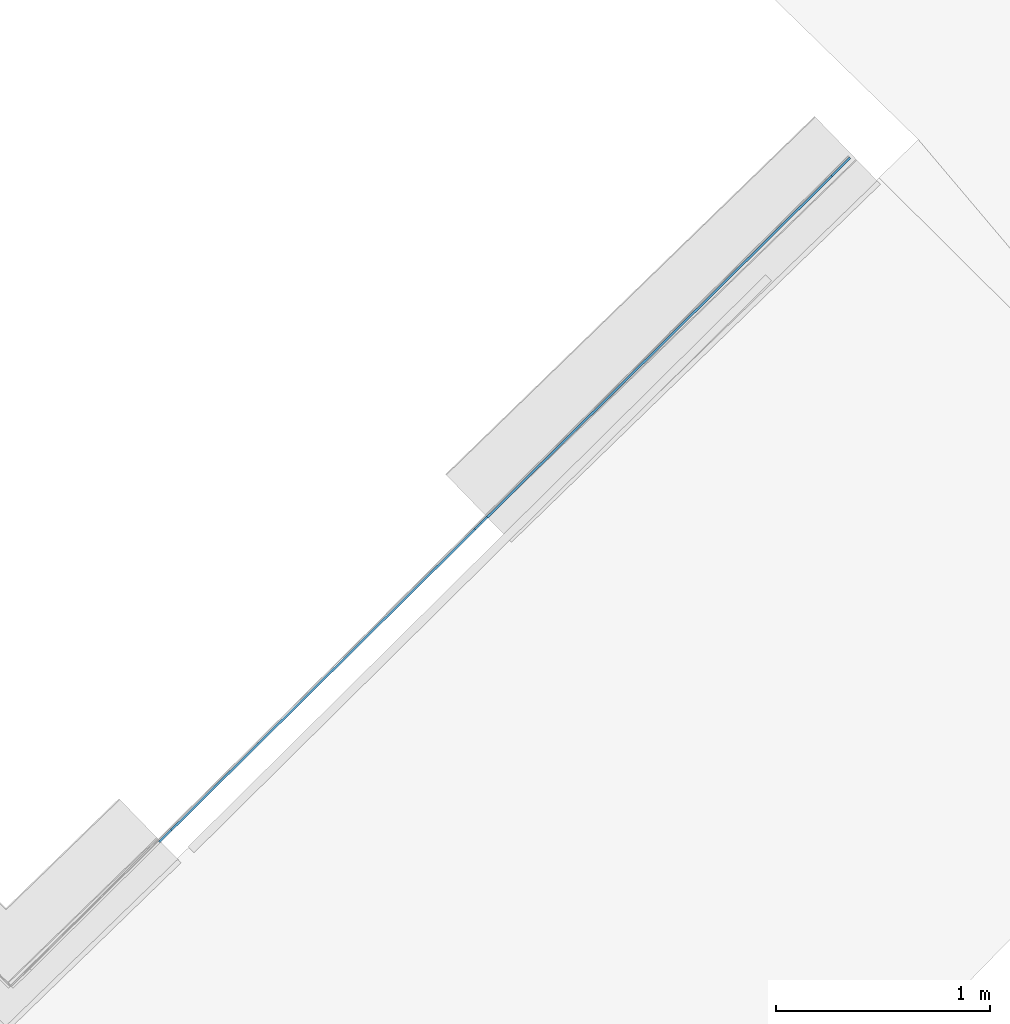
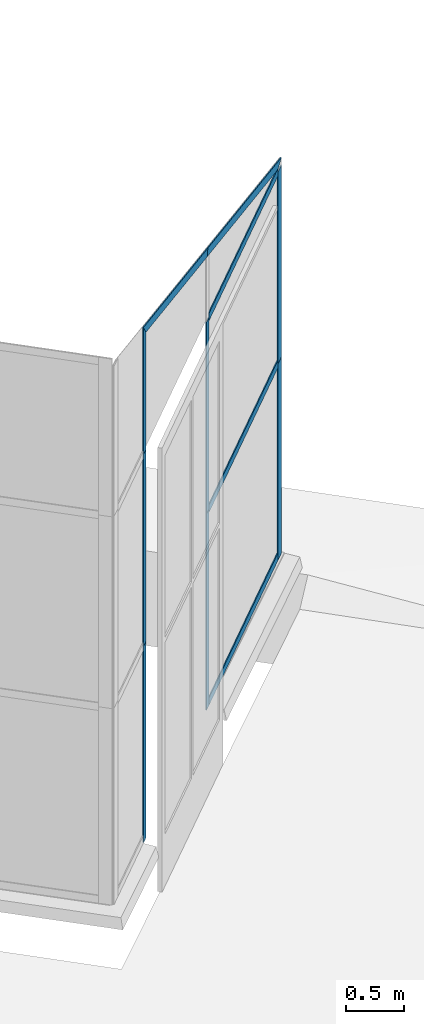
# One storey, part 3 of 13: 12 members, 1 element without a shape of its own.
"""IFC4 building model written with IfcOpenShell, lengths in metres."""

from ifc_helpers import new_model, entity, si_unit, converted_unit, direction, frame, origin, place, context, subcontext, project, spatial, indexed_curve, outline, extrude, source, transform, mapped, material, type_object, type_shapes, element, aggregate, save


model = new_model("IFC4")

# Units and contexts
model_context = context("Model", 3, precision=1e-05, world=origin(), true_north=direction((6.123233995736766e-17, 1.0)))
body_context = subcontext(model_context, "Body", "Model", "MODEL_VIEW")
ifc_project = project(units=[si_unit("LENGTHUNIT", "METRE"), si_unit("AREAUNIT", "SQUARE_METRE"), si_unit("VOLUMEUNIT", "CUBIC_METRE"), converted_unit("PLANEANGLEUNIT", "DEGREE", entity("IfcPlaneAngleMeasure", 0.017453292519943278), si_unit("PLANEANGLEUNIT", "RADIAN"), dimensions=[0, 0, 0, 0, 0, 0, 0])], contexts=[model_context])

# Site, building, storey
site_placement = place(None, frame((0.0, 0.0, 0.0), z_axis=(0.0, 0.0, 1.0), x_axis=(0.7160934825303189, -0.6980043870045516, 0.0)))
site = spatial("IfcSite", under=ifc_project, at=site_placement, CompositionType="ELEMENT")
building_placement = place(site_placement, origin())
building = spatial("IfcBuilding", under=site, at=building_placement, CompositionType="ELEMENT")
storey_placement = place(building_placement, frame((0.0, 0.0, -7.0)))
storey = spatial("IfcBuildingStorey", under=building, at=storey_placement, Name="-7.00 m", CompositionType="ELEMENT", Elevation=-7.000000000000001)

# Curtain wall, members
curtain_wall_type = type_object("IfcCurtainWallType", Name="Facciata continua:Vetrata_1", PredefinedType="NOTDEFINED")
curtain_wall_placement = place(storey_placement, frame((0.0, 0.0, 7.0)))
curtain_wall = element("IfcCurtainWall", 1, at=curtain_wall_placement, inside=storey, type_object=curtain_wall_type, Name="Facciata continua:Vetrata_1", ObjectType="Facciata continua:Vetrata_1", PredefinedType="NOTDEFINED")
ifc_material = material(Name="Acciaio", Category="Metallo")
member_type_1 = type_object("IfcMemberType", Name="Montante rettangolare:Montante rettangolare 3", PredefinedType="MULLION", material=ifc_material)
shared_shape_1 = source(origin(), body_context, "Body", "SweptSolid", [
    extrude(outline(indexed_curve([(-0.06, -0.004999999999999997), (0.06, -0.004999999999999997), (0.06, 0.004999999999999997), (-0.06, 0.004999999999999997), (-0.06, -0.004999999999999997)], self_intersect=False)), frame((-0.06, 0.009999999999999993, -2.0800000000000005), z_axis=(0.0, 0.0, 1.0), x_axis=(-1.0, 0.0, 0.0)), (0.0, 0.0, 1.0), 2.0800000000000005),
])
type_shapes(member_type_1, [shared_shape_1])
member_1_placement = place(curtain_wall_placement, frame((8.439099009840033, -1.4710459050843856, -6.94), z_axis=(0.0, 0.0, -1.0), x_axis=(0.017636182236115534, 0.9998444704433458, 0.0)))
member_1 = element("IfcMember", 2, at=member_1_placement, type_object=member_type_1, material=ifc_material, Name="Montante rettangolare:Montante rettangolare 3", ObjectType="Montante rettangolare:Montante rettangolare 3", PredefinedType="MULLION", context=body_context, shape_type="MappedRepresentation", body=[
    mapped(shared_shape_1, transform((0.0, 0.0, 0.0), scale=1.0)),
])
member_type_2 = type_object("IfcMemberType", Name="Montante rettangolare:Montante rettangolare 3", PredefinedType="MULLION", material=ifc_material)
shared_shape_2 = source(origin(), body_context, "Body", "SweptSolid", [
    extrude(outline(indexed_curve([(-0.06, -0.004999999999999997), (0.06, -0.004999999999999997), (0.06, 0.004999999999999997), (-0.06, 0.004999999999999997), (-0.06, -0.004999999999999997)], self_intersect=False)), frame((-0.06, 0.009999999999999993, -2.030000000000001), z_axis=(0.0, 0.0, 1.0), x_axis=(-1.0, 0.0, 0.0)), (0.0, 0.0, 1.0), 2.030000000000001),
])
type_shapes(member_type_2, [shared_shape_2])
member_2_placement = place(curtain_wall_placement, frame((8.439099009840033, -1.4710459050843856, -4.86), z_axis=(0.0, 0.0, -1.0), x_axis=(0.017636182236115534, 0.9998444704433458, 0.0)))
member_2 = element("IfcMember", 3, at=member_2_placement, type_object=member_type_2, material=ifc_material, Name="Montante rettangolare:Montante rettangolare 3", ObjectType="Montante rettangolare:Montante rettangolare 3", PredefinedType="MULLION", context=body_context, shape_type="MappedRepresentation", body=[
    mapped(shared_shape_2, transform((0.0, 0.0, 0.0), scale=1.0)),
])
member_type_3 = type_object("IfcMemberType", Name="Montante rettangolare:Montante rettangolare 2", PredefinedType="MULLION", material=ifc_material)
shared_shape_3 = source(origin(), body_context, "Body", "SweptSolid", [
    extrude(outline(indexed_curve([(-1.284408025415731, -0.04), (1.2332732224483656, -0.04), (1.2332732224483656, 0.04), (-1.1821384194810003, 0.04), (-1.284408025415731, -0.04)], self_intersect=False)), frame((-0.04, 0.004999999999999997, -1.28440802541573), z_axis=(0.0, 1.0, 0.0), x_axis=(0.0, 0.0, -1.0)), (0.0, 0.0, 1.0), 0.010000000000000002),
])
type_shapes(member_type_3, [shared_shape_3])
member_3_placement = place(curtain_wall_placement, frame((8.439099009840035, -1.4710459050843858, -2.750831472247348), z_axis=(0.016988025387663693, 0.9630986468728898, -0.26861199411984027), x_axis=(0.004737290079103897, 0.26857021701548284, 0.9632484604788959)))
member_3 = element("IfcMember", 4, at=member_3_placement, type_object=member_type_3, material=ifc_material, Name="Montante rettangolare:Montante rettangolare 2", ObjectType="Montante rettangolare:Montante rettangolare 2", PredefinedType="MULLION", context=body_context, shape_type="MappedRepresentation", body=[
    mapped(shared_shape_3, transform((0.0, 0.0, 0.0), scale=1.0)),
])
member_type_4 = type_object("IfcMemberType", Name="Montante rettangolare:Montante rettangolare 2", PredefinedType="MULLION", material=ifc_material)
shared_shape_4 = source(origin(), body_context, "Body", "SweptSolid", [
    extrude(outline(indexed_curve([(-1.0724492417537428, -0.04), (1.1251298136381405, -0.04), (1.0197686698693456, 0.04), (-1.072449241753743, 0.04), (-1.0724492417537428, -0.04)], self_intersect=False)), frame((-0.04, 0.004999999999999997, -1.072449241753743), z_axis=(0.0, 1.0, 0.0), x_axis=(0.0, 0.0, -1.0)), (0.0, 0.0, 1.0), 0.01000000000000001),
])
type_shapes(member_type_4, [shared_shape_4])
member_4_placement = place(curtain_wall_placement, frame((8.396328576883272, -3.895821308159543, -2.074552091700445), z_axis=(0.0169880253876632, 0.9630986468728896, -0.2686119941198403), x_axis=(0.004737290079103898, 0.26857021701548284, 0.9632484604788958)))
member_4 = element("IfcMember", 5, at=member_4_placement, type_object=member_type_4, material=ifc_material, Name="Montante rettangolare:Montante rettangolare 2", ObjectType="Montante rettangolare:Montante rettangolare 2", PredefinedType="MULLION", context=body_context, shape_type="MappedRepresentation", body=[
    mapped(shared_shape_4, transform((0.0, 0.0, 0.0), scale=1.0)),
])
member_type_5 = type_object("IfcMemberType", Name="Montante rettangolare:Montante rettangolare 2", PredefinedType="MULLION", material=ifc_material)
shared_shape_5 = source(origin(), body_context, "Body", "SweptSolid", [
    extrude(outline(indexed_curve([(-0.04, -0.005000000000000005), (0.04, -0.005000000000000005), (0.04, 0.005000000000000005), (-0.04, 0.005000000000000005), (-0.04, -0.005000000000000005)], self_intersect=False)), frame((-0.04, 0.010000000000000002, -2.265152585981675), z_axis=(0.0, 0.0, 1.0), x_axis=(-1.0, 0.0, 0.0)), (0.0, 0.0, 1.0), 2.265152585981675),
])
type_shapes(member_type_5, [shared_shape_5])
member_5_placement = place(curtain_wall_placement, frame((8.397034024172717, -3.85582752934181, -6.94), z_axis=(-0.017636182236115693, -0.9998444704433458, 0.0), x_axis=(0.0, 0.0, -1.0)))
member_5 = element("IfcMember", 6, at=member_5_placement, type_object=member_type_5, material=ifc_material, Name="Montante rettangolare:Montante rettangolare 2", ObjectType="Montante rettangolare:Montante rettangolare 2", PredefinedType="MULLION", context=body_context, shape_type="MappedRepresentation", body=[
    mapped(shared_shape_5, transform((0.0, 0.0, 0.0), scale=1.0)),
])
member_type_6 = type_object("IfcMemberType", Name="Montante rettangolare:Montante rettangolare 2", PredefinedType="MULLION", material=ifc_material)
shared_shape_6 = source(origin(), body_context, "Body", "SweptSolid", [
    extrude(outline(indexed_curve([(-0.04, -0.005000000000000001), (0.04, -0.005000000000000001), (0.04, 0.005000000000000001), (-0.04, 0.005000000000000001), (-0.04, -0.005000000000000001)], self_intersect=False)), frame((0.0, 0.009999999999999998, -2.265152585981675), z_axis=(0.0, 0.0, 1.0), x_axis=(-1.0, 0.0, 0.0)), (0.0, 0.0, 1.0), 2.265152585981675),
])
type_shapes(member_type_6, [shared_shape_6])
member_6_placement = place(curtain_wall_placement, frame((8.436982667971696, -1.591027241537587, -2.829999999999999), z_axis=(0.017636182236115693, 0.9998444704433458, 0.0), x_axis=(0.0, 0.0, 1.0)))
member_6 = element("IfcMember", 7, at=member_6_placement, type_object=member_type_6, material=ifc_material, Name="Montante rettangolare:Montante rettangolare 2", ObjectType="Montante rettangolare:Montante rettangolare 2", PredefinedType="MULLION", context=body_context, shape_type="MappedRepresentation", body=[
    mapped(shared_shape_6, transform((0.0, 0.0, 0.0), scale=1.0)),
])
member_7_placement = place(curtain_wall_placement, frame((8.436982667971696, -1.591027241537587, -4.86), z_axis=(0.017636182236115693, 0.9998444704433458, 0.0), x_axis=(0.0, 0.0, 1.0)))
member_7 = element("IfcMember", 8, at=member_7_placement, type_object=member_type_6, material=ifc_material, Name="Montante rettangolare:Montante rettangolare 2", ObjectType="Montante rettangolare:Montante rettangolare 2", PredefinedType="MULLION", context=body_context, shape_type="MappedRepresentation", body=[
    mapped(shared_shape_6, transform((0.0, 0.0, 0.0), scale=1.0)),
])
member_type_7 = type_object("IfcMemberType", Name="Montante rettangolare:Montante rettangolare 2", PredefinedType="MULLION", material=ifc_material)
shared_shape_7 = source(origin(), body_context, "Body", "SweptSolid", [
    extrude(outline(indexed_curve([(-0.04, -0.005000000000000001), (0.04, -0.005000000000000001), (0.04, 0.005000000000000001), (-0.04, 0.005000000000000001), (-0.04, -0.005000000000000001)], self_intersect=False)), frame((0.0, 0.009999999999999998, -2.0800000000000005), z_axis=(0.0, 0.0, 1.0), x_axis=(-1.0, 0.0, 0.0)), (0.0, 0.0, 1.0), 2.0800000000000005),
])
type_shapes(member_type_7, [shared_shape_7])
member_8_placement = place(curtain_wall_placement, frame((8.359701495388325, -5.972312943985936, -6.94), z_axis=(0.0, 0.0, -1.0), x_axis=(0.017636182236115534, 0.9998444704433458, 0.0)))
member_8 = element("IfcMember", 9, at=member_8_placement, type_object=member_type_7, material=ifc_material, Name="Montante rettangolare:Montante rettangolare 2", ObjectType="Montante rettangolare:Montante rettangolare 2", PredefinedType="MULLION", context=body_context, shape_type="MappedRepresentation", body=[
    mapped(shared_shape_7, transform((0.0, 0.0, 0.0), scale=1.0)),
])
member_9_placement = place(curtain_wall_placement, frame((8.396328576883272, -3.895821308159544, -6.94), z_axis=(0.0, 0.0, -1.0), x_axis=(0.017636182236115534, 0.9998444704433458, 0.0)))
member_9 = element("IfcMember", 10, at=member_9_placement, type_object=member_type_7, material=ifc_material, Name="Montante rettangolare:Montante rettangolare 2", ObjectType="Montante rettangolare:Montante rettangolare 2", PredefinedType="MULLION", context=body_context, shape_type="MappedRepresentation", body=[
    mapped(shared_shape_7, transform((0.0, 0.0, 0.0), scale=1.0)),
])
member_type_8 = type_object("IfcMemberType", Name="Montante rettangolare:Montante rettangolare 2", PredefinedType="MULLION", material=ifc_material)
shared_shape_8 = source(origin(), body_context, "Body", "SweptSolid", [
    extrude(outline(indexed_curve([(-0.6465317143599824, -0.04), (0.593851142475585, -0.04), (0.6992122862443798, 0.04), (-0.6465317143599824, 0.04), (-0.6465317143599824, -0.04)], self_intersect=False)), frame((0.0, 0.004999999999999997, -0.6465317143599824), z_axis=(0.0, 1.0, 0.0), x_axis=(0.0, 0.0, -1.0)), (0.0, 0.0, 1.0), 0.010000000000000002),
])
type_shapes(member_type_8, [shared_shape_8])
member_10_placement = place(curtain_wall_placement, frame((8.359701495388325, -5.972312943985936, -2.829999999999999), z_axis=(0.0, 0.0, -1.0), x_axis=(0.017636182236115534, 0.9998444704433458, 0.0)))
member_10 = element("IfcMember", 11, at=member_10_placement, type_object=member_type_8, material=ifc_material, Name="Montante rettangolare:Montante rettangolare 2", ObjectType="Montante rettangolare:Montante rettangolare 2", PredefinedType="MULLION", context=body_context, shape_type="MappedRepresentation", body=[
    mapped(shared_shape_8, transform((0.0, 0.0, 0.0), scale=1.0)),
])
member_type_9 = type_object("IfcMemberType", Name="Montante rettangolare:Montante rettangolare 2", PredefinedType="MULLION", material=ifc_material)
shared_shape_9 = source(origin(), body_context, "Body", "SweptSolid", [
    extrude(outline(indexed_curve([(-0.04, -0.005000000000000001), (0.04, -0.005000000000000001), (0.04, 0.005000000000000001), (-0.04, 0.005000000000000001), (-0.04, -0.005000000000000001)], self_intersect=False)), frame((0.0, 0.009999999999999998, -2.030000000000001), z_axis=(0.0, 0.0, 1.0), x_axis=(-1.0, 0.0, 0.0)), (0.0, 0.0, 1.0), 2.030000000000001),
])
type_shapes(member_type_9, [shared_shape_9])
member_11_placement = place(curtain_wall_placement, frame((8.359701495388325, -5.972312943985936, -4.86), z_axis=(0.0, 0.0, -1.0), x_axis=(0.017636182236115534, 0.9998444704433458, 0.0)))
member_11 = element("IfcMember", 12, at=member_11_placement, type_object=member_type_9, material=ifc_material, Name="Montante rettangolare:Montante rettangolare 2", ObjectType="Montante rettangolare:Montante rettangolare 2", PredefinedType="MULLION", context=body_context, shape_type="MappedRepresentation", body=[
    mapped(shared_shape_9, transform((0.0, 0.0, 0.0), scale=1.0)),
])
member_12_placement = place(curtain_wall_placement, frame((8.396328576883272, -3.895821308159544, -4.86), z_axis=(0.0, 0.0, -1.0), x_axis=(0.017636182236115534, 0.9998444704433458, 0.0)))
member_12 = element("IfcMember", 13, at=member_12_placement, type_object=member_type_9, material=ifc_material, Name="Montante rettangolare:Montante rettangolare 2", ObjectType="Montante rettangolare:Montante rettangolare 2", PredefinedType="MULLION", context=body_context, shape_type="MappedRepresentation", body=[
    mapped(shared_shape_9, transform((0.0, 0.0, 0.0), scale=1.0)),
])
aggregate(curtain_wall, [member_3, member_4, member_5, member_1, member_6, member_8, member_9, member_10, member_2, member_11, member_12, member_7])

save(model, "model.ifc")
